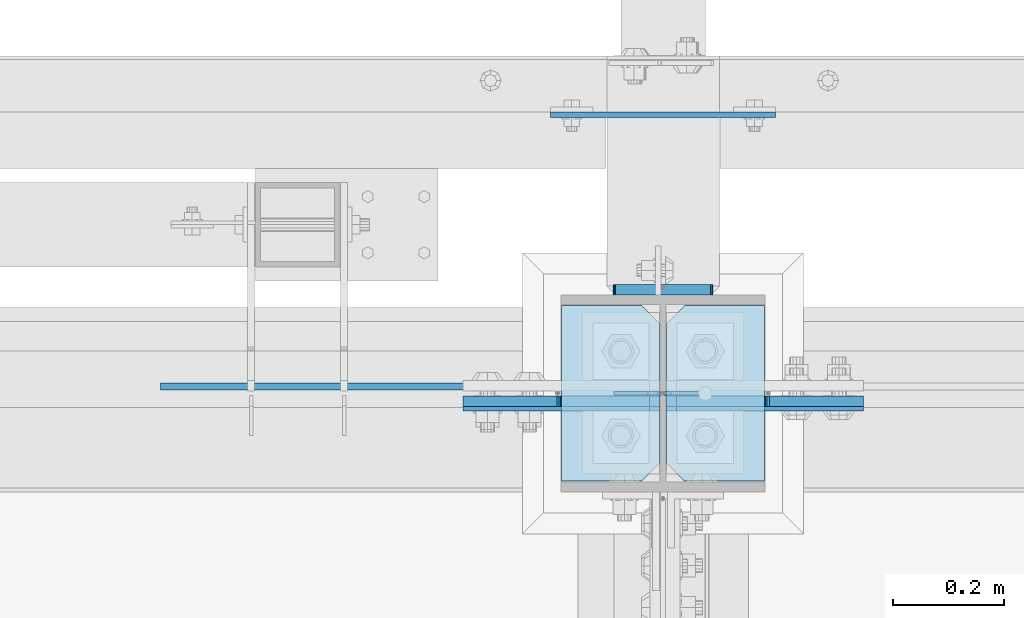
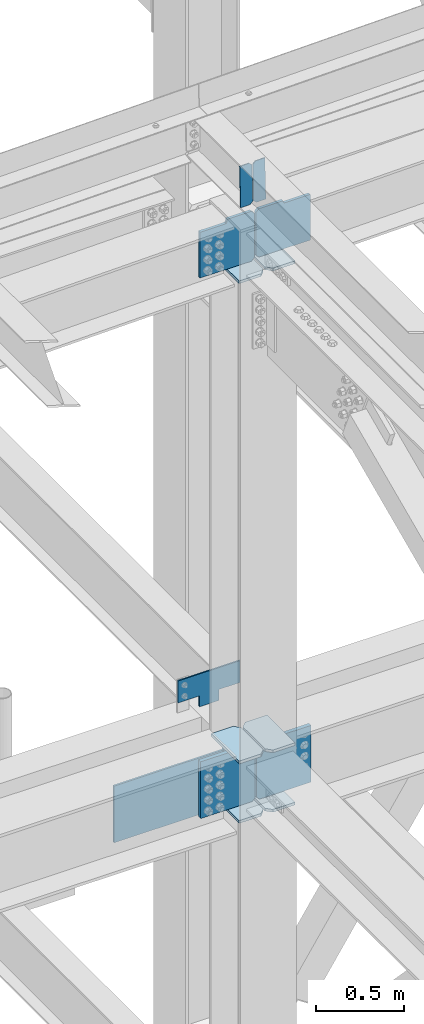
# One storey, part 3506 of 3843: 15 plates, 3 elements without a shape of their own.
"""IFC2X3 building model written with IfcOpenShell, lengths in millimetres."""

from ifc_helpers import new_model, si_unit, frame, origin_with_axes, place, context, subcontext, project, spatial, faceted_brep, material, type_object, element, aggregate, save


model = new_model("IFC2X3")

# Units and contexts
model_context = context("Model", 3, precision=1e-05, world=origin_with_axes())
body_context = subcontext(model_context, "Body", "Model", "MODEL_VIEW")
ifc_project = project(units=[si_unit("LENGTHUNIT", "METRE", prefix="MILLI"), si_unit("AREAUNIT", "SQUARE_METRE"), si_unit("VOLUMEUNIT", "CUBIC_METRE"), si_unit("MASSUNIT", "GRAM", prefix="KILO"), si_unit("TIMEUNIT", "SECOND"), si_unit("PLANEANGLEUNIT", "RADIAN"), si_unit("SOLIDANGLEUNIT", "STERADIAN"), si_unit("THERMODYNAMICTEMPERATUREUNIT", "DEGREE_CELSIUS"), si_unit("LUMINOUSINTENSITYUNIT", "LUMEN")], contexts=[model_context])

# Site, building, storey
site_placement = place(None, origin_with_axes())
site = spatial("IfcSite", under=ifc_project, at=site_placement, CompositionType="ELEMENT")
building_placement = place(site_placement, origin_with_axes())
building = spatial("IfcBuilding", under=site, at=building_placement, Name="Undefined", CompositionType="ELEMENT")
storey_placement = place(building_placement, origin_with_axes())
storey = spatial("IfcBuildingStorey", under=building, at=storey_placement, Name="Undefined", CompositionType="ELEMENT", Elevation=0.0)

# Assembly, plates
assembly_1_placement = place(storey_placement, origin_with_axes())
assembly_1 = element("IfcElementAssembly", 1, at=assembly_1_placement, inside=storey, Name="COLUMN", AssemblyPlace="NOTDEFINED", PredefinedType="RIGID_FRAME")
ifc_material = material(Name="STEEL/A572-50")
plate_type_1 = type_object("IfcPlateType", PredefinedType="NOTDEFINED")
plate_1_placement = place(assembly_1_placement, frame((70250.84375, 92195.6500000954, 42411.65), z_axis=(-1.0, 0.0, 0.0), x_axis=(0.0, 0.0, -1.0)))
plate_1 = element("IfcPlate", 2, at=plate_1_placement, type_object=plate_type_1, material=ifc_material, Name="PLATE", context=body_context, shape_type="Brep", body=[
    faceted_brep([(0.0, -12.6999999999971, 19.0499992370605), (0.0, -12.6999999999971, 356.393737792969), (0.0, 12.6999999999971, 356.393737792969), (0.0, 12.6999999999971, 19.0499992370605), (393.700012207031, -12.6999999999971, 356.393737792969), (393.700012207031, 12.6999999999971, 356.393737792969), (393.700012207031, -12.6999999999971, 19.0499992370605), (393.700012207031, 12.6999999999971, 19.0499992370605), (374.650012969971, -12.6999999999971, 0.0), (374.650012969971, 12.6999999999971, 0.0), (19.0500015258731, -12.6999999999971, -6.33008312433958e-10), (19.0500015258731, 12.6999999999971, 0.0)], [[[0, 1, 2, 3]], [[1, 4, 5, 2]], [[4, 6, 7, 5]], [[6, 8, 9, 7]], [[8, 10, 11, 9]], [[10, 0, 3, 11]], [[5, 7, 9, 11, 3, 2]], [[10, 8, 6, 4, 1, 0]]]),
])
plate_2_placement = place(assembly_1_placement, frame((70261.95625, 92195.6500000954, 42411.65), z_axis=(1.0, 0.0, 0.0), x_axis=(0.0, 0.0, -1.0)))
plate_2 = element("IfcPlate", 3, at=plate_2_placement, type_object=plate_type_1, material=ifc_material, Name="PLATE", context=body_context, shape_type="Brep", body=[
    faceted_brep([(0.0, -12.6999999999971, 19.0499992370605), (0.0, -12.6999999999971, 356.393737792969), (0.0, 12.6999999999971, 356.393737792969), (0.0, 12.6999999999971, 19.0499992370605), (393.700012207031, -12.6999999999971, 356.393737792969), (393.700012207031, 12.6999999999971, 356.393737792969), (393.700012207031, -12.6999999999971, 19.0499992370605), (393.700012207031, 12.6999999999971, 19.0499992370605), (374.650012969971, -12.6999999999971, 0.0), (374.650012969971, 12.6999999999971, 0.0), (19.0500015258731, -12.6999999999971, -6.33008312433958e-10), (19.0500015258731, 12.6999999999971, 0.0)], [[[0, 1, 2, 3]], [[1, 4, 5, 2]], [[4, 6, 7, 5]], [[6, 8, 9, 7]], [[8, 10, 11, 9]], [[10, 0, 3, 11]], [[5, 7, 9, 11, 3, 2]], [[10, 8, 6, 4, 1, 0]]]),
])

assembly_2_placement = place(storey_placement, origin_with_axes())
assembly_2 = element("IfcElementAssembly", 4, at=assembly_2_placement, inside=storey, Name="BEAM", AssemblyPlace="NOTDEFINED", PredefinedType="RIGID_FRAME")
plate_type_2 = type_object("IfcPlateType", PredefinedType="NOTDEFINED")
plate_3_placement = place(assembly_2_placement, frame((70338.6964783814, 92214.1041243654, 46144.9234819168), z_axis=(-0.0211520977514592, 0.00183800499970675, 0.999774579842043), x_axis=(-0.999776269352655, -3.88860000349027e-05, -0.021152062007432)))
plate_3 = element("IfcPlate", 5, at=plate_3_placement, type_object=plate_type_2, material=ifc_material, Name="STIFFENER", context=body_context, shape_type="Brep", body=[
    faceted_brep([(0.0, -3.17499999999927, 0.0), (6.83940015733242e-10, -3.17499999996653, 288.924999998613), (6.54836185276508e-10, 3.17500000001746, 288.924999998591), (0.0, 3.17499999999927, 0.0), (61.9125003828667, -3.17499999997744, 288.924999998599), (61.9125003828522, 3.17500000002838, 288.924999998584), (79.3750000013097, -3.17499999997744, 271.462500380039), (79.375000001266, 3.17500000002838, 271.462500380017), (79.375000000713, -3.17499999999927, 17.4624996185448), (79.3750000006694, 3.17500000000291, 17.462499618523), (61.9125003821828, -3.17499999999563, -1.45519152283669e-11), (61.9125003821682, 3.17500000000655, -2.91038304567337e-11)], [[[0, 1, 2, 3]], [[1, 4, 5, 2]], [[4, 6, 7, 5]], [[6, 8, 9, 7]], [[8, 10, 11, 9]], [[10, 0, 3, 11]], [[5, 7, 9, 11, 3, 2]], [[10, 8, 6, 4, 1, 0]]]),
])
plate_4_placement = place(assembly_2_placement, frame((70252.9906576911, 92214.1007908313, 46143.1102213802), z_axis=(-0.0211520977514592, 0.00183800499970675, 0.999774579842043), x_axis=(-0.999776269352655, -3.88860000349027e-05, -0.021152062007432)))
plate_4 = element("IfcPlate", 6, at=plate_4_placement, type_object=plate_type_2, material=ifc_material, Name="STIFFENER", context=body_context, shape_type="Brep", body=[
    faceted_brep([(5.82076609134674e-11, -3.17499999999927, 17.4624996185667), (6.25732354819775e-10, -3.17499999997744, 271.462500380054), (5.82076609134674e-10, 3.17500000002474, 271.462500380039), (0.0, 3.17500000000655, 17.4624996185521), (17.462499619156, -3.17499999997744, 288.924999998606), (17.4624996191269, 3.17500000002474, 288.924999998591), (79.3750000013242, -3.17500000025029, 288.924999998591), (79.3750000013097, 3.1749999997337, 288.92499999857), (79.3750000006548, -3.17500000026484, -2.18278728425503e-11), (79.3750000006403, 3.17499999969732, -2.91038304567337e-11), (17.4624996184866, -3.17500000000291, 7.27595761418343e-12), (17.462499618443, 3.17500000000291, -7.27595761418343e-12)], [[[0, 1, 2, 3]], [[1, 4, 5, 2]], [[4, 6, 7, 5]], [[6, 8, 9, 7]], [[8, 10, 11, 9]], [[10, 0, 3, 11]], [[5, 7, 9, 11, 3, 2]], [[10, 8, 6, 4, 1, 0]]]),
])
aggregate(assembly_2, [plate_3, plate_4])

# Plate
plate_type_3 = type_object("IfcPlateType", PredefinedType="NOTDEFINED")
plate_5_placement = place(assembly_1_placement, frame((70073.04375, 92373.45, 42008.425), z_axis=(0.0, -1.0, 0.0), x_axis=(1.0, 0.0, 0.0)))
plate_5 = element("IfcPlate", 7, at=plate_5_placement, type_object=plate_type_3, material=ifc_material, Name="PLATE", context=body_context, shape_type="Brep", body=[
    faceted_brep([(0.0, -9.52500000000146, 0.0), (0.0, -9.52500000000146, 317.5), (0.0, 9.52500000000146, 317.5), (0.0, 9.52500000000146, 0.0), (144.462501525879, -9.52500000000146, 317.5), (144.462501525879, 9.52500000000146, 317.5), (177.800003051758, -9.52500000000146, 284.162498474121), (177.800003051758, 9.52500000000146, 284.162498474121), (177.800003051758, -9.52500000000146, 33.3375015258789), (177.800003051758, 9.52500000000146, 33.3375015258789), (144.462501525879, -9.52500000000146, 0.0), (144.462501525879, 9.52500000000146, 0.0)], [[[0, 1, 2, 3]], [[1, 4, 5, 2]], [[4, 6, 7, 5]], [[6, 8, 9, 7]], [[8, 10, 11, 9]], [[10, 0, 3, 11]], [[5, 7, 9, 11, 3, 2]], [[10, 8, 6, 4, 1, 0]]]),
])

plate_6_placement = place(assembly_1_placement, frame((70073.04375, 92373.45, 42421.175), z_axis=(0.0, -1.0, 0.0), x_axis=(1.0, 0.0, 0.0)))
plate_6 = element("IfcPlate", 8, at=plate_6_placement, type_object=plate_type_3, material=ifc_material, Name="PLATE", context=body_context, shape_type="Brep", body=[
    faceted_brep([(0.0, -9.52500000000146, 0.0), (0.0, -9.52500000000146, 317.5), (0.0, 9.52500000000146, 317.5), (0.0, 9.52500000000146, 0.0), (144.462501525879, -9.52500000000146, 317.5), (144.462501525879, 9.52500000000146, 317.5), (177.800003051758, -9.52500000000146, 284.162498474121), (177.800003051758, 9.52500000000146, 284.162498474121), (177.800003051758, -9.52500000000146, 33.3375015258789), (177.800003051758, 9.52500000000146, 33.3375015258789), (144.462501525879, -9.52500000000146, 0.0), (144.462501525879, 9.52500000000146, 0.0)], [[[0, 1, 2, 3]], [[1, 4, 5, 2]], [[4, 6, 7, 5]], [[6, 8, 9, 7]], [[8, 10, 11, 9]], [[10, 0, 3, 11]], [[5, 7, 9, 11, 3, 2]], [[10, 8, 6, 4, 1, 0]]]),
])

plate_7_placement = place(assembly_1_placement, frame((70439.75625, 92055.95, 42008.425), z_axis=(0.0, 1.0, 0.0), x_axis=(-1.0, 0.0, 0.0)))
plate_7 = element("IfcPlate", 9, at=plate_7_placement, type_object=plate_type_3, material=ifc_material, Name="PLATE", context=body_context, shape_type="Brep", body=[
    faceted_brep([(0.0, -9.52500000000146, 0.0), (0.0, -9.52500000000146, 317.5), (0.0, 9.52500000000146, 317.5), (0.0, 9.52500000000146, 0.0), (144.462501525879, -9.52500000000146, 317.5), (144.462501525879, 9.52500000000146, 317.5), (177.800003051758, -9.52500000000146, 284.162498474121), (177.800003051758, 9.52500000000146, 284.162498474121), (177.800003051758, -9.52500000000146, 33.3375015258789), (177.800003051758, 9.52500000000146, 33.3375015258789), (144.462501525879, -9.52500000000146, 0.0), (144.462501525879, 9.52500000000146, 0.0)], [[[0, 1, 2, 3]], [[1, 4, 5, 2]], [[4, 6, 7, 5]], [[6, 8, 9, 7]], [[8, 10, 11, 9]], [[10, 0, 3, 11]], [[5, 7, 9, 11, 3, 2]], [[10, 8, 6, 4, 1, 0]]]),
])

plate_8_placement = place(assembly_1_placement, frame((70439.75625, 92055.95, 42421.175), z_axis=(0.0, 1.0, 0.0), x_axis=(-1.0, 0.0, 0.0)))
plate_8 = element("IfcPlate", 10, at=plate_8_placement, type_object=plate_type_3, material=ifc_material, Name="PLATE", context=body_context, shape_type="Brep", body=[
    faceted_brep([(0.0, -9.52500000000146, 0.0), (0.0, -9.52500000000146, 317.5), (0.0, 9.52500000000146, 317.5), (0.0, 9.52500000000146, 0.0), (144.462501525879, -9.52500000000146, 317.5), (144.462501525879, 9.52500000000146, 317.5), (177.800003051758, -9.52500000000146, 284.162498474121), (177.800003051758, 9.52500000000146, 284.162498474121), (177.800003051758, -9.52500000000146, 33.3375015258789), (177.800003051758, 9.52500000000146, 33.3375015258789), (144.462501525879, -9.52500000000146, 0.0), (144.462501525879, 9.52500000000146, 0.0)], [[[0, 1, 2, 3]], [[1, 4, 5, 2]], [[4, 6, 7, 5]], [[6, 8, 9, 7]], [[8, 10, 11, 9]], [[10, 0, 3, 11]], [[5, 7, 9, 11, 3, 2]], [[10, 8, 6, 4, 1, 0]]]),
])

plate_9_placement = place(assembly_1_placement, frame((70439.75625, 92055.95, 45765.129706899), z_axis=(0.0, 1.0, 0.0), x_axis=(-1.0, 0.0, 0.0)))
plate_9 = element("IfcPlate", 11, at=plate_9_placement, type_object=plate_type_3, material=ifc_material, Name="PLATE", context=body_context, shape_type="Brep", body=[
    faceted_brep([(0.0, -9.52500000000146, 0.0), (0.0, -9.52500000000146, 317.5), (0.0, 9.52500000000146, 317.5), (0.0, 9.52500000000146, 0.0), (144.462501525879, -9.52500000000146, 317.5), (144.462501525879, 9.52500000000146, 317.5), (177.800003051758, -9.52500000000146, 284.162498474121), (177.800003051758, 9.52500000000146, 284.162498474121), (177.800003051758, -9.52500000000146, 33.3375015258789), (177.800003051758, 9.52500000000146, 33.3375015258789), (144.462501525879, -9.52500000000146, 0.0), (144.462501525879, 9.52500000000146, 0.0)], [[[0, 1, 2, 3]], [[1, 4, 5, 2]], [[4, 6, 7, 5]], [[6, 8, 9, 7]], [[8, 10, 11, 9]], [[10, 0, 3, 11]], [[5, 7, 9, 11, 3, 2]], [[10, 8, 6, 4, 1, 0]]]),
])

plate_10_placement = place(assembly_1_placement, frame((70073.0437499884, 92373.4499999999, 45753.6252590556), z_axis=(0.0, -1.0, 0.0), x_axis=(1.0, 0.0, 0.0)))
plate_10 = element("IfcPlate", 12, at=plate_10_placement, type_object=plate_type_3, material=ifc_material, Name="PLATE", context=body_context, shape_type="Brep", body=[
    faceted_brep([(0.0, -9.52500000000146, 0.0), (0.0, -9.52500000000146, 317.5), (0.0, 9.52500000000146, 317.5), (0.0, 9.52500000000146, 0.0), (144.462501525879, -9.52500000000146, 317.5), (144.462501525879, 9.52500000000146, 317.5), (177.800003051758, -9.52500000000146, 284.162498474121), (177.800003051758, 9.52500000000146, 284.162498474121), (177.800003051758, -9.52500000000146, 33.3375015258789), (177.800003051758, 9.52500000000146, 33.3375015258789), (144.462501525879, -9.52500000000146, 0.0), (144.462501525879, 9.52500000000146, 0.0)], [[[0, 1, 2, 3]], [[1, 4, 5, 2]], [[4, 6, 7, 5]], [[6, 8, 9, 7]], [[8, 10, 11, 9]], [[10, 0, 3, 11]], [[5, 7, 9, 11, 3, 2]], [[10, 8, 6, 4, 1, 0]]]),
])

plate_type_4 = type_object("IfcPlateType", PredefinedType="NOTDEFINED")
plate_11_placement = place(assembly_1_placement, frame((70192.9, 92717.9375, 42367.2), z_axis=(0.0, 0.0, 1.0), x_axis=(1.0, 0.0, 0.0)))
plate_11 = element("IfcPlate", 13, at=plate_11_placement, type_object=plate_type_4, material=ifc_material, Name="PLATE", context=body_context, shape_type="Brep", body=[
    faceted_brep([(0.0, -4.76249999999709, 0.0), (-3.49245965480804e-10, -4.76249999999709, 76.1999999999462), (-3.49245965480804e-10, 4.76249999999709, 76.1999999999462), (0.0, 4.76249999999709, 0.0), (-139.699996948242, -4.76249999999709, 76.1999969482422), (-139.699996948242, 4.76249999999709, 76.1999969482422), (-139.699996948242, -4.76249999999709, 228.600006103516), (-139.699996948242, 4.76249999999709, 228.600006103516), (266.700012207031, -4.76249999999709, 228.600006103516), (266.700012207031, 4.76249999999709, 228.600006103516), (266.700012207031, -4.76249999999709, 76.1999969482422), (266.700012207031, 4.76249999999709, 76.1999969482422), (126.999992370605, -4.76249999999709, 76.1999969482422), (126.999992370605, 4.76249999999709, 76.1999969482422), (126.999992370605, -4.76249999999709, 0.0), (126.999992370605, 4.76249999999709, 0.0)], [[[0, 1, 2, 3]], [[1, 4, 5, 2]], [[4, 6, 7, 5]], [[6, 8, 9, 7]], [[8, 10, 11, 9]], [[10, 12, 13, 11]], [[12, 14, 15, 13]], [[14, 0, 3, 15]], [[5, 7, 9, 11, 13, 15, 3, 2]], [[14, 12, 10, 8, 6, 4, 1, 0]]]),
])

plate_type_5 = type_object("IfcPlateType", PredefinedType="NOTDEFINED")
plate_12_placement = place(assembly_1_placement, frame((70165.9125, 92402.025, 42356.4551879883), z_axis=(1.0, 0.0, 0.0), x_axis=(0.0, 0.0, -1.0)))
plate_12 = element("IfcPlate", 14, at=plate_12_placement, type_object=plate_type_5, material=ifc_material, Name="PLATE", context=body_context, shape_type="Brep", body=[
    faceted_brep([(-8.22591685395256e-13, -9.52499999999854, 7.9375), (0.0, -9.52499999999418, 173.037499999991), (0.0, 9.52499999999418, 173.037499999991), (0.0, 9.52499999999418, 7.9375), (0.604206210693519, -9.52499999999418, 176.075049744395), (0.604206210693519, 9.52499999999418, 176.075049744395), (2.32483992433117, -9.52499999999418, 178.65016007566), (2.32483992433117, 9.52499999999418, 178.65016007566), (4.89995025560347, -9.52499999999418, 180.370793789305), (4.89995025560347, 9.52499999999418, 180.370793789305), (7.9375, -9.52499999999418, 180.974999999991), (7.9375, 9.52499999999418, 180.974999999991), (274.637499999997, -9.52499999999418, 180.974999999991), (274.637499999997, 9.52499999999418, 180.974999999991), (277.675049744394, -9.52499999999418, 180.370793789305), (277.675049744394, 9.52499999999418, 180.370793789305), (280.250160075666, -9.52499999999418, 178.65016007566), (280.250160075666, 9.52499999999418, 178.65016007566), (281.970793789304, -9.52499999999418, 176.075049744395), (281.970793789304, 9.52499999999418, 176.075049744395), (282.574999999997, -9.52499999999418, 173.037499999991), (282.574999999997, 9.52499999999418, 173.037499999991), (282.574999999997, -9.52499999999418, 7.9375), (282.574999999997, 9.52499999999418, 7.9375), (281.970793789304, -9.52499999999418, 4.8999502555962), (281.970793789304, 9.52499999999418, 4.8999502555962), (280.250160075666, -9.52499999999418, 2.32483992433117), (280.250160075666, 9.52499999999418, 2.32483992433117), (277.675049744394, -9.52499999999418, 0.604206210686243), (277.675049744394, 9.52499999999418, 0.604206210686243), (274.637499999997, -9.52499999999418, 0.0), (274.637499999997, 9.52499999999418, 0.0), (7.9375, -9.52499999999854, 0.0), (7.9375, 9.52499999999418, 0.0), (4.8999502555962, -9.52499999999418, 0.604206210693519), (4.8999502555962, 9.52499999999418, 0.604206210693519), (2.32483992433117, -9.52499999999418, 2.32483992433117), (2.32483992433117, 9.52499999999418, 2.32483992433117), (0.604206210686243, -9.52499999999418, 4.89995025560347), (0.604206210686243, 9.52499999999418, 4.89995025560347)], [[[0, 1, 2, 3]], [[1, 4, 5, 2]], [[4, 6, 7, 5]], [[6, 8, 9, 7]], [[8, 10, 11, 9]], [[10, 12, 13, 11]], [[12, 14, 15, 13]], [[14, 16, 17, 15]], [[16, 18, 19, 17]], [[18, 20, 21, 19]], [[20, 22, 23, 21]], [[22, 24, 25, 23]], [[24, 26, 27, 25]], [[26, 28, 29, 27]], [[28, 30, 31, 29]], [[30, 32, 33, 31]], [[32, 34, 35, 33]], [[34, 36, 37, 35]], [[36, 38, 39, 37]], [[38, 0, 3, 39]], [[5, 7, 9, 11, 13, 15, 17, 19, 21, 23, 25, 27, 29, 31, 33, 35, 37, 39, 3, 2]], [[38, 36, 34, 32, 30, 28, 26, 24, 22, 20, 18, 16, 14, 12, 10, 8, 6, 4, 1, 0]]]),
])

# Assembly, plate
assembly_3_placement = place(storey_placement, origin_with_axes())
assembly_3 = element("IfcElementAssembly", 15, at=assembly_3_placement, inside=storey, Name="BEAM", AssemblyPlace="NOTDEFINED", PredefinedType="RIGID_FRAME")
plate_type_6 = type_object("IfcPlateType", PredefinedType="NOTDEFINED")
plate_13_placement = place(assembly_3_placement, frame((70059.55, 92227.4, 42017.949987793), z_axis=(0.0, 0.0, 1.0), x_axis=(-1.0, 0.0, 0.0)))
plate_13 = element("IfcPlate", 16, at=plate_13_placement, type_object=plate_type_6, material=ifc_material, Name="PLATE", context=body_context, shape_type="Brep", body=[
    faceted_brep([(0.0, -6.3499999046162, 0.0), (0.0, -6.34999999999854, 393.700012207031), (0.0, 6.34999999999854, 393.700012207031), (7.27595761418343e-12, 6.3499999046162, 0.0), (711.199999999968, -6.35000000000582, 393.700012207031), (711.200000000012, 6.34999999999854, 393.700000000004), (711.199999999968, -6.35000000000582, 0.0), (711.199999999997, 6.34999999999854, 0.0)], [[[0, 1, 2, 3]], [[1, 4, 5, 2]], [[4, 6, 7, 5]], [[6, 0, 3, 7]], [[7, 3, 2, 5]], [[6, 4, 1, 0]]]),
])
aggregate(assembly_3, [plate_13])

# Plate
plate_type_7 = type_object("IfcPlateType", PredefinedType="NOTDEFINED")
plate_14_placement = place(assembly_1_placement, frame((70261.95625, 92200.4124996185, 45793.7047068729), z_axis=(0.707106781186548, 0.0, 0.707106781186548), x_axis=(0.707106781186548, 0.0, -0.707106781186548)))
plate_14 = element("IfcPlate", 17, at=plate_14_placement, type_object=plate_type_7, material=ifc_material, Name="PLATE", context=body_context, shape_type="Brep", body=[
    faceted_brep([(0.0, -9.52500000000146, 0.0), (-209.979301496754, -9.52500000000146, 209.979301496671), (-209.979301496754, 9.52500000000146, 209.979301496671), (0.0, 9.52500000000146, 0.0), (-209.979301496471, -9.52500000000146, 236.920069860033), (-209.979301496471, 9.52500000000146, 236.920069860033), (-97.1648339737767, -9.52500000000146, 349.734537382756), (-97.1648339737767, 9.52500000000146, 349.734537382756), (-93.3396839560301, -9.52500000000146, 345.909387365013), (-93.3396839560301, 9.52500000000146, 345.909387365013), (-89.219507487891, -9.52500000000146, 343.156373464546), (-89.219507487891, 9.52500000000146, 343.156373464546), (-84.35942796983, -9.52500000000146, 342.189643541991), (-84.35942796983, 9.52500000000146, 342.189643541991), (-79.4993484517727, -9.52500000000146, 343.15637346459), (-79.4993484517727, 9.52500000000146, 343.15637346459), (-75.3791719835863, -9.52500000000146, 345.909387365115), (-75.3791719835863, 9.52500000000146, 345.909387365115), (41.3641577270682, -9.52500000000146, 462.652717075805), (41.3641577270682, 9.52500000000146, 462.652717075805), (265.870560752759, -9.52500000000146, 238.146314050202), (265.870560752759, 9.52500000000146, 238.146314050202), (26.9407683632344, -9.52499999999964, 2.03726813197136e-10), (26.9407683632344, 9.52499999999964, 2.03726813197136e-10)], [[[0, 1, 2, 3]], [[1, 4, 5, 2]], [[4, 6, 7, 5]], [[6, 8, 9, 7]], [[8, 10, 11, 9]], [[10, 12, 13, 11]], [[12, 14, 15, 13]], [[14, 16, 17, 15]], [[16, 18, 19, 17]], [[18, 20, 21, 19]], [[20, 22, 23, 21]], [[22, 0, 3, 23]], [[5, 7, 9, 11, 13, 15, 17, 19, 21, 23, 3, 2]], [[22, 20, 18, 16, 14, 12, 10, 8, 6, 4, 1, 0]]]),
])

plate_type_8 = type_object("IfcPlateType", PredefinedType="NOTDEFINED")
plate_15_placement = place(assembly_1_placement, frame((70250.8437499999, 92200.4124996185, 45782.2002589406), z_axis=(-0.707106781186548, 0.0, 0.707106781186548), x_axis=(-0.707106781186548, 0.0, -0.707106781186548)))
plate_15 = element("IfcPlate", 18, at=plate_15_placement, type_object=plate_type_8, material=ifc_material, Name="PLATE", context=body_context, shape_type="Brep", body=[
    faceted_brep([(0.0, -9.52500000000146, 0.0), (-217.83702560261, -9.52500000000146, 217.837025602606), (-217.83702560261, 9.52500000000146, 217.837025602606), (0.0, 9.52500000000146, 0.0), (-217.837025602319, -9.52500000000146, 244.777793965968), (-217.837025602319, 9.52500000000146, 244.777793965968), (-105.02255807961, -9.52500000000146, 357.592261488677), (-105.02255807961, 9.52500000000146, 357.592261488677), (-94.254791630985, -9.52500000000146, 346.824495040062), (-94.254791630985, 9.52500000000146, 346.824495040062), (-90.1346151628532, -9.52500000000146, 344.071481139596), (-90.1346151628532, 9.52500000000146, 344.071481139596), (-85.2745356447995, -9.52500000000146, 343.104751217026), (-85.2745356447995, 9.52500000000146, 343.104751217026), (-80.4144561267167, -9.52500000000146, 344.07148113965), (-80.4144561267167, 9.52500000000146, 344.07148113965), (-76.2942796585558, -9.52500000000146, 346.824495040149), (-76.2942796585558, 9.52500000000146, 346.824495040149), (40.4490500521206, -9.52500000000146, 463.567824750826), (40.4490500521206, 9.52500000000146, 463.567824750826), (264.955453077768, -9.52500000000146, 239.061421725179), (264.955453077768, 9.52500000000146, 239.061421725179), (26.9407683632344, -9.52499999999964, 2.03726813197136e-10), (26.9407683632344, 9.52499999999964, 2.03726813197136e-10)], [[[0, 1, 2, 3]], [[1, 4, 5, 2]], [[4, 6, 7, 5]], [[6, 8, 9, 7]], [[8, 10, 11, 9]], [[10, 12, 13, 11]], [[12, 14, 15, 13]], [[14, 16, 17, 15]], [[16, 18, 19, 17]], [[18, 20, 21, 19]], [[20, 22, 23, 21]], [[22, 0, 3, 23]], [[5, 7, 9, 11, 13, 15, 17, 19, 21, 23, 3, 2]], [[22, 20, 18, 16, 14, 12, 10, 8, 6, 4, 1, 0]]]),
])

aggregate(assembly_1, [plate_12, plate_11, plate_5, plate_6, plate_1, plate_7, plate_8, plate_2, plate_9, plate_14, plate_10, plate_15])

save(model, "model.ifc")
